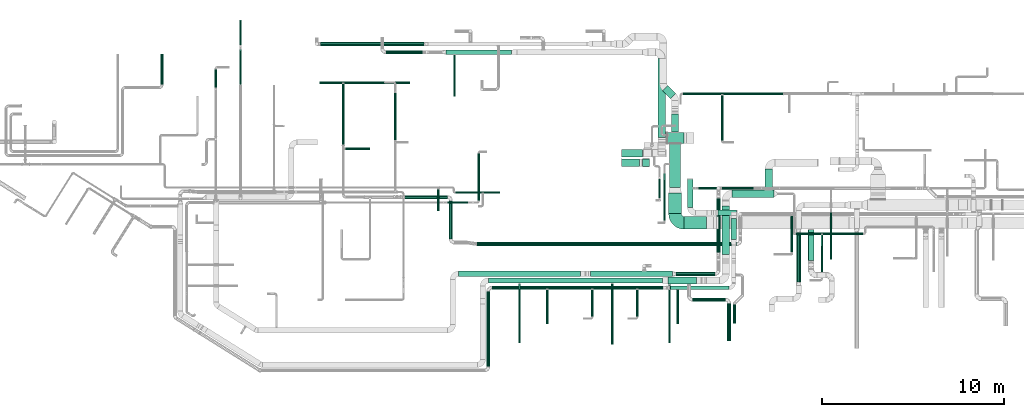
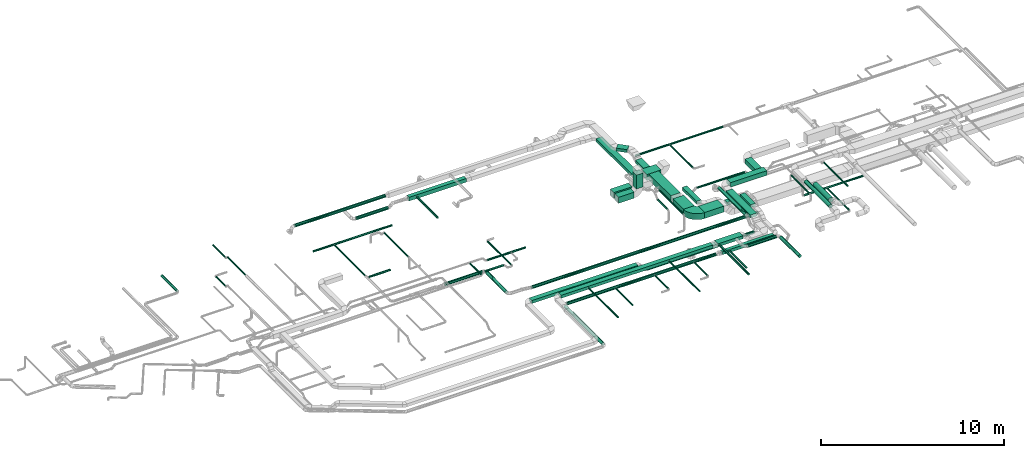
# One storey, part 2 of 60: 65 flow segments, 1 flow fitting.
"""IFC2X3 building model written with IfcOpenShell, lengths in millimetres."""

from ifc_helpers import new_model, entity, si_unit, converted_unit, derived_unit, direction, frame, frame_2d, origin, origin_2d_with_axis, place, context, subcontext, project, spatial, polyline, circle_curve, parameter, trimmed, segment, composite_curve, rectangle, circle, outline, extrude, source, transform, mapped, material, type_object, type_shapes, element, save


model = new_model("IFC2X3")

# Units and contexts
model_context = context("Model", 3, precision=0.01, world=origin(), true_north=direction((6.12303176911189e-17, 1.0)))
body_context = subcontext(model_context, "Body", "Model", "MODEL_VIEW")
ifc_project = project(units=[si_unit("LENGTHUNIT", "METRE", prefix="MILLI"), si_unit("AREAUNIT", "SQUARE_METRE"), si_unit("VOLUMEUNIT", "CUBIC_METRE"), converted_unit("PLANEANGLEUNIT", "DEGREE", entity("IfcRatioMeasure", 0.0174532925199433), si_unit("PLANEANGLEUNIT", "RADIAN"), dimensions=[0, 0, 0, 0, 0, 0, 0]), si_unit("MASSUNIT", "GRAM", prefix="KILO"), derived_unit("MASSDENSITYUNIT", [(si_unit("MASSUNIT", "GRAM", prefix="KILO"), 1), (si_unit("LENGTHUNIT", "METRE"), -3)]), derived_unit("MOMENTOFINERTIAUNIT", [(si_unit("LENGTHUNIT", "METRE"), 4)]), si_unit("TIMEUNIT", "SECOND"), si_unit("FREQUENCYUNIT", "HERTZ"), si_unit("THERMODYNAMICTEMPERATUREUNIT", "DEGREE_CELSIUS"), derived_unit("THERMALTRANSMITTANCEUNIT", [(si_unit("MASSUNIT", "GRAM", prefix="KILO"), 1), (si_unit("THERMODYNAMICTEMPERATUREUNIT", "KELVIN"), -1), (si_unit("TIMEUNIT", "SECOND"), -3)]), derived_unit("VOLUMETRICFLOWRATEUNIT", [(si_unit("LENGTHUNIT", "METRE"), 3), (si_unit("TIMEUNIT", "SECOND"), -1)]), derived_unit("MASSFLOWRATEUNIT", [(si_unit("MASSUNIT", "GRAM", prefix="KILO"), 1), (si_unit("TIMEUNIT", "SECOND"), -1)]), derived_unit("ROTATIONALFREQUENCYUNIT", [(si_unit("TIMEUNIT", "SECOND"), -1)]), si_unit("ELECTRICCURRENTUNIT", "AMPERE"), si_unit("ELECTRICVOLTAGEUNIT", "VOLT"), si_unit("POWERUNIT", "WATT"), si_unit("FORCEUNIT", "NEWTON", prefix="KILO"), si_unit("ILLUMINANCEUNIT", "LUX"), si_unit("LUMINOUSFLUXUNIT", "LUMEN"), si_unit("LUMINOUSINTENSITYUNIT", "CANDELA"), derived_unit("USERDEFINED", [(si_unit("MASSUNIT", "GRAM", prefix="KILO"), -1), (si_unit("LENGTHUNIT", "METRE"), -2), (si_unit("TIMEUNIT", "SECOND"), 3), (si_unit("LUMINOUSFLUXUNIT", "LUMEN"), 1)]), derived_unit("LINEARVELOCITYUNIT", [(si_unit("LENGTHUNIT", "METRE"), 1), (si_unit("TIMEUNIT", "SECOND"), -1)]), si_unit("PRESSUREUNIT", "PASCAL"), derived_unit("USERDEFINED", [(si_unit("LENGTHUNIT", "METRE"), -2), (si_unit("MASSUNIT", "GRAM", prefix="KILO"), 1), (si_unit("TIMEUNIT", "SECOND"), -2)]), derived_unit("LINEARFORCEUNIT", [(si_unit("MASSUNIT", "GRAM", prefix="KILO"), 1), (si_unit("LENGTHUNIT", "METRE"), 1), (si_unit("TIMEUNIT", "SECOND"), -2), (si_unit("LENGTHUNIT", "METRE"), -1)]), derived_unit("PLANARFORCEUNIT", [(si_unit("MASSUNIT", "GRAM", prefix="KILO"), 1), (si_unit("LENGTHUNIT", "METRE"), 1), (si_unit("TIMEUNIT", "SECOND"), -2), (si_unit("LENGTHUNIT", "METRE"), -2)])], contexts=[model_context])

# Site, building, storey
site_placement = place(None, origin())
site = spatial("IfcSite", under=ifc_project, at=site_placement, CompositionType="ELEMENT")
building_placement = place(site_placement, origin())
building = spatial("IfcBuilding", under=site, at=building_placement, CompositionType="ELEMENT")
storey_placement = place(building_placement, frame((0.0, 0.0, 19800.0)))
storey = spatial("IfcBuildingStorey", under=building, at=storey_placement, CompositionType="ELEMENT", Elevation=19800.0)

# Flow segments
duct_segment_type_1 = type_object("IfcDuctSegmentType", PredefinedType="NOTDEFINED")
flow_segment_1_placement = place(storey_placement, frame((31902.9, 5435.05, 3500.0)))
element("IfcFlowSegment", 1, at=flow_segment_1_placement, inside=storey, type_object=duct_segment_type_1, context=body_context, shape_type="SweptSolid", body=[
    extrude(rectangle(XDim=6701.44660940672, YDim=300.0, at=origin_2d_with_axis()), frame((3350.72, 150.0, 0.0)), (0.0, 0.0, 1.0), 199.999999999998),
])
flow_segment_2_placement = place(storey_placement, frame((39161.45, 5435.05, 3150.0)))
element("IfcFlowSegment", 2, at=flow_segment_2_placement, inside=storey, type_object=duct_segment_type_1, context=body_context, shape_type="SweptSolid", body=[
    extrude(rectangle(XDim=4491.44660940676, YDim=300.0, at=origin_2d_with_axis()), frame((2245.72, 150.0, 0.0), z_axis=(0.0, 0.0, 1.0), x_axis=(-1.0, 0.0, 0.0)), (0.0, 0.0, 1.0), 199.999999999998),
])
flow_segment_3_placement = place(storey_placement, frame((48721.97, 10205.34, 3350.0)))
element("IfcFlowSegment", 3, at=flow_segment_3_placement, inside=storey, type_object=duct_segment_type_1, context=body_context, shape_type="SweptSolid", body=[
    extrude(rectangle(XDim=1129.99999999999, YDim=400.000000000004, at=origin_2d_with_axis()), frame((200.0, 565.0, 0.0), z_axis=(0.0, 0.0, 1.0), x_axis=(0.0, -1.0, 0.0)), (0.0, 0.0, 1.0), 300.000000000001),
])
flow_segment_4_placement = place(storey_placement, frame((43391.97, 5025.34, 3500.0)))
element("IfcFlowSegment", 4, at=flow_segment_4_placement, inside=storey, type_object=duct_segment_type_1, context=body_context, shape_type="SweptSolid", body=[
    extrude(rectangle(XDim=1576.57160940675, YDim=400.0, at=origin_2d_with_axis()), frame((788.29, 200.0, 0.0), z_axis=(0.0, 0.0, 1.0), x_axis=(-1.0, 0.0, 0.0)), (0.0, 0.0, 1.0), 199.999999999998),
])
flow_segment_5_placement = place(storey_placement, frame((46370.09, 6645.9, 3400.0)))
element("IfcFlowSegment", 5, at=flow_segment_5_placement, inside=storey, type_object=duct_segment_type_1, context=body_context, shape_type="SweptSolid", body=[
    extrude(rectangle(XDim=2659.44660940663, YDim=400.000000000004, at=origin_2d_with_axis()), frame((200.0, 1329.72, 0.0), z_axis=(0.0, 0.0, 1.0), x_axis=(0.0, -1.0, 0.0)), (0.0, 0.0, 1.0), 199.999999999998),
])
flow_segment_6_placement = place(storey_placement, frame((46920.09, 9785.34, 3350.0)))
element("IfcFlowSegment", 6, at=flow_segment_6_placement, inside=storey, type_object=duct_segment_type_1, context=body_context, shape_type="SweptSolid", body=[
    extrude(rectangle(XDim=2301.875, YDim=400.0, at=origin_2d_with_axis()), frame((1150.94, 200.0, 0.0)), (0.0, 0.0, 1.0), 300.000000000001),
])
flow_segment_7_placement = place(storey_placement, frame((44470.22, 9235.84, 3400.0)))
element("IfcFlowSegment", 7, at=flow_segment_7_placement, inside=storey, type_object=duct_segment_type_1, context=body_context, shape_type="SweptSolid", body=[
    extrude(rectangle(XDim=1545.99428870432, YDim=300.000000000001, at=origin_2d_with_axis()), frame((150.0, 773.0, 0.0), z_axis=(0.0, 0.0, 1.0), x_axis=(0.0, 1.0, 0.0)), (0.0, 0.0, 1.0), 199.999999999998),
])
flow_segment_8_placement = place(storey_placement, frame((43488.88, 4724.52, 3119.89)))
element("IfcFlowSegment", 8, at=flow_segment_8_placement, inside=storey, type_object=duct_segment_type_1, context=body_context, shape_type="SweptSolid", body=[
    extrude(rectangle(XDim=3266.49248887751, YDim=200.000000000001, at=origin_2d_with_axis()), frame((1633.25, 100.0, 0.0), z_axis=(0.0, 0.0, 1.0), x_axis=(-1.0, 0.0, 0.0)), (0.0, 0.0, 1.0), 199.999999999998),
])
flow_segment_9_placement = place(storey_placement, frame((40859.97, 11999.48, 3370.0)))
element("IfcFlowSegment", 9, at=flow_segment_9_placement, inside=storey, type_object=duct_segment_type_1, context=body_context, shape_type="SweptSolid", body=[
    extrude(rectangle(XDim=1150.20548678296, YDim=400.0, at=origin_2d_with_axis()), frame((575.1, 200.0, 0.0), z_axis=(0.0, 0.0, 1.0), x_axis=(-1.0, 0.0, 0.0)), (0.0, 0.0, 1.0), 400.000000000004),
])
flow_segment_10_placement = place(storey_placement, frame((42853.67, 13078.03, 3200.0)))
element("IfcFlowSegment", 10, at=flow_segment_10_placement, inside=storey, type_object=duct_segment_type_1, context=body_context, shape_type="SweptSolid", body=[
    extrude(rectangle(XDim=4322.32864376273, YDim=400.000000000004, at=origin_2d_with_axis()), frame((200.0, 2161.16, 0.0), z_axis=(0.0, 0.0, 1.0), x_axis=(0.0, 1.0, 0.0)), (0.0, 0.0, 1.0), 199.999999999998),
])
flow_segment_11_placement = place(storey_placement, frame((31213.67, 17625.36, 3175.0)))
element("IfcFlowSegment", 11, at=flow_segment_11_placement, inside=storey, type_object=duct_segment_type_1, context=body_context, shape_type="SweptSolid", body=[
    extrude(rectangle(XDim=3599.99999999994, YDim=249.999999999999, at=origin_2d_with_axis()), frame((1800.0, 125.0, 0.0), z_axis=(0.0, 0.0, 1.0), x_axis=(-1.0, 0.0, 0.0)), (0.0, 0.0, 1.0), 250.000000000004),
])
flow_segment_12_placement = place(storey_placement, frame((43366.87, 12737.27, 3250.0)))
element("IfcFlowSegment", 12, at=flow_segment_12_placement, inside=storey, type_object=duct_segment_type_1, context=body_context, shape_type="SweptSolid", body=[
    extrude(rectangle(XDim=903.436285348532, YDim=600.0, at=origin_2d_with_axis()), frame((451.72, 300.0, 0.0), z_axis=(0.0, 0.0, 1.0), x_axis=(-1.0, 0.0, 0.0)), (0.0, 0.0, 1.0), 399.999999999996),
])
flow_segment_13_placement = place(storey_placement, frame((43105.14, 15194.37, 3550.0)))
element("IfcFlowSegment", 13, at=flow_segment_13_placement, inside=storey, type_object=duct_segment_type_1, context=body_context, shape_type="SweptSolid", body=[
    extrude(rectangle(XDim=625.405845398155, YDim=400.000000000001, at=origin_2d_with_axis()), frame((362.54, 362.54, 0.0), z_axis=(0.0, 0.0, 1.0), x_axis=(-0.707106781186548, 0.707106781186548, 0.0)), (0.0, 0.0, 1.0), 199.999999999998),
])
flow_segment_14_placement = place(storey_placement, frame((43591.3, 13357.27, 3350.0)))
element("IfcFlowSegment", 14, at=flow_segment_14_placement, inside=storey, type_object=duct_segment_type_1, context=body_context, shape_type="SweptSolid", body=[
    extrude(rectangle(XDim=1010.48600992803, YDim=399.999999999996, at=origin_2d_with_axis()), frame((200.0, 505.24, 0.0), z_axis=(0.0, 0.0, 1.0), x_axis=(0.0, 1.0, 0.0)), (0.0, 0.0, 1.0), 199.999999999998),
])
flow_segment_15_placement = place(storey_placement, frame((43490.59, 10335.7, 3250.0)))
element("IfcFlowSegment", 15, at=flow_segment_15_placement, inside=storey, type_object=duct_segment_type_1, context=body_context, shape_type="SweptSolid", body=[
    extrude(rectangle(XDim=2381.56802559638, YDim=600.000000000002, at=origin_2d_with_axis()), frame((300.0, 1190.78, 0.0), z_axis=(0.0, 0.0, 1.0), x_axis=(0.0, -1.0, 0.0)), (0.0, 0.0, 1.0), 399.999999999996),
])
flow_segment_16_placement = place(storey_placement, frame((43440.59, 8889.45, 3250.0)))
element("IfcFlowSegment", 16, at=flow_segment_16_placement, inside=storey, type_object=duct_segment_type_1, context=body_context, shape_type="SweptSolid", body=[
    extrude(rectangle(XDim=1146.24999999992, YDim=699.999999999997, at=origin_2d_with_axis()), frame((350.0, 573.12, 0.0), z_axis=(0.0, 0.0, 1.0), x_axis=(0.0, -1.0, 0.0)), (0.0, 0.0, 1.0), 400.000000000004),
])
flow_segment_17_placement = place(storey_placement, frame((44290.59, 8039.45, 3250.0)))
element("IfcFlowSegment", 17, at=flow_segment_17_placement, inside=storey, type_object=duct_segment_type_1, context=body_context, shape_type="SweptSolid", body=[
    extrude(rectangle(XDim=1215.02518618001, YDim=700.0, at=origin_2d_with_axis()), frame((607.51, 350.0, 0.0)), (0.0, 0.0, 1.0), 400.000000000004),
])
flow_segment_18_placement = place(storey_placement, frame((33546.97, 5075.34, 3500.0)))
element("IfcFlowSegment", 18, at=flow_segment_18_placement, inside=storey, type_object=duct_segment_type_1, context=body_context, shape_type="SweptSolid", body=[
    extrude(rectangle(XDim=9544.99999999996, YDim=300.0, at=origin_2d_with_axis()), frame((4772.5, 150.0, 0.0), z_axis=(0.0, 0.0, 1.0), x_axis=(-1.0, 0.0, 0.0)), (0.0, 0.0, 1.0), 199.999999999998),
])
flow_segment_19_placement = place(storey_placement, frame((46855.37, 7462.65, 3410.0)))
element("IfcFlowSegment", 19, at=flow_segment_19_placement, inside=storey, type_object=duct_segment_type_1, context=body_context, shape_type="SweptSolid", body=[
    extrude(rectangle(XDim=1173.37972851492, YDim=300.000000000001, at=origin_2d_with_axis()), frame((150.0, 586.69, 0.0), z_axis=(0.0, 0.0, 1.0), x_axis=(0.0, 1.0, 0.0)), (0.0, 0.0, 1.0), 199.999999999998),
])
flow_segment_20_placement = place(storey_placement, frame((46139.36, 8786.03, 3017.42)))
element("IfcFlowSegment", 20, at=flow_segment_20_placement, inside=storey, type_object=duct_segment_type_1, context=body_context, shape_type="SweptSolid", body=[
    extrude(rectangle(XDim=1027.5, YDim=300.0, at=origin_2d_with_axis()), frame((513.75, 150.0, 0.0)), (0.0, 0.0, 1.0), 199.999999999998),
])
flow_segment_21_placement = place(storey_placement, frame((40859.97, 11490.3, 3370.0)))
element("IfcFlowSegment", 21, at=flow_segment_21_placement, inside=storey, type_object=duct_segment_type_1, context=body_context, shape_type="SweptSolid", body=[
    extrude(rectangle(XDim=987.66925228846, YDim=400.0, at=origin_2d_with_axis()), frame((493.83, 200.0, 0.0)), (0.0, 0.0, 1.0), 400.000000000004),
])
flow_segment_22_placement = place(storey_placement, frame((41997.64, 11490.3, 3920.0)))
element("IfcFlowSegment", 22, at=flow_segment_22_placement, inside=storey, type_object=duct_segment_type_1, context=body_context, shape_type="SweptSolid", body=[
    extrude(rectangle(XDim=399.999999999996, YDim=400.0, at=origin_2d_with_axis()), frame((200.0, 200.0, 0.0)), (0.0, 0.0, 1.0), 929.999975000012),
])
duct_segment_type_2 = type_object("IfcDuctSegmentType", PredefinedType="NOTDEFINED")
flow_segment_23_placement = place(storey_placement, frame((15568.44, 15966.64, 3568.4)))
element("IfcFlowSegment", 23, at=flow_segment_23_placement, inside=storey, type_object=duct_segment_type_2, context=body_context, shape_type="SweptSolid", body=[
    extrude(circle(Radius=80.0, at=origin_2d_with_axis()), frame((81.6, 0.0, 81.6), z_axis=(0.0, 1.0, 0.0), x_axis=(1.0, 0.0, 0.0)), (0.0, 0.0, 1.0), 1673.75000000002),
])
flow_segment_24_placement = place(storey_placement, frame((31747.19, 9998.68, 3598.4)))
element("IfcFlowSegment", 24, at=flow_segment_24_placement, inside=storey, type_object=duct_segment_type_2, context=body_context, shape_type="SweptSolid", body=[
    extrude(circle(Radius=50.0, at=origin_2d_with_axis()), frame((0.0, 51.6, 51.6), z_axis=(1.0, 0.0, 0.0), x_axis=(0.0, -1.0, 0.0)), (0.0, 0.0, 1.0), 2422.49999999999),
])
flow_segment_25_placement = place(storey_placement, frame((30742.73, 9042.46, 3598.4)))
element("IfcFlowSegment", 25, at=flow_segment_25_placement, inside=storey, type_object=duct_segment_type_2, context=body_context, shape_type="SweptSolid", body=[
    extrude(circle(Radius=50.0, at=origin_2d_with_axis()), frame((51.6, 0.0, 51.6), z_axis=(0.0, 1.0, 0.0), x_axis=(-1.0, 0.0, 0.0)), (0.0, 0.0, 1.0), 1199.99999999992),
])
flow_segment_26_placement = place(storey_placement, frame((19903.44, 15963.91, 3148.33)))
element("IfcFlowSegment", 26, at=flow_segment_26_placement, inside=storey, type_object=duct_segment_type_2, context=body_context, shape_type="SweptSolid", body=[
    extrude(circle(Radius=50.0, at=origin_2d_with_axis()), frame((51.6, 0.0, 51.6), z_axis=(0.0, 1.0, 0.0), x_axis=(1.0, 0.0, 0.0)), (0.0, 0.0, 1.0), 1943.57864376271),
])
flow_segment_27_placement = place(storey_placement, frame((19903.44, 18140.26, 2998.4)))
element("IfcFlowSegment", 27, at=flow_segment_27_placement, inside=storey, type_object=duct_segment_type_2, context=body_context, shape_type="SweptSolid", body=[
    extrude(circle(Radius=50.0, at=origin_2d_with_axis()), frame((51.6, 0.0, 51.6), z_axis=(0.0, 1.0, 0.0), x_axis=(1.0, 0.0, 0.0)), (0.0, 0.0, 1.0), 1373.36076977577),
])
flow_segment_28_placement = place(storey_placement, frame((43852.9, 5483.46, 3148.4)))
element("IfcFlowSegment", 28, at=flow_segment_28_placement, inside=storey, type_object=duct_segment_type_2, context=body_context, shape_type="SweptSolid", body=[
    extrude(circle(Radius=100.0, at=origin_2d_with_axis()), frame((0.0, 101.6, 101.6), z_axis=(1.0, 0.0, 0.0), x_axis=(0.0, -1.0, 0.0)), (0.0, 0.0, 1.0), 2117.5),
])
flow_segment_29_placement = place(storey_placement, frame((32973.55, 9600.18, 3098.4)))
element("IfcFlowSegment", 29, at=flow_segment_29_placement, inside=storey, type_object=duct_segment_type_2, context=body_context, shape_type="SweptSolid", body=[
    extrude(circle(Radius=50.0, at=origin_2d_with_axis()), frame((51.6, 0.0, 51.6), z_axis=(0.0, 1.0, 0.0), x_axis=(1.0, 0.0, 0.0)), (0.0, 0.0, 1.0), 2591.87500000001),
])
flow_segment_30_placement = place(storey_placement, frame((31284.07, 9448.58, 3348.4)))
element("IfcFlowSegment", 30, at=flow_segment_30_placement, inside=storey, type_object=duct_segment_type_2, context=body_context, shape_type="SweptSolid", body=[
    extrude(circle(Radius=50.0, at=origin_2d_with_axis()), frame((0.0, 51.6, 51.6), z_axis=(1.0, 0.0, 0.0), x_axis=(0.0, 1.0, 0.0)), (0.0, 0.0, 1.0), 1163.15728752536),
])
flow_segment_31_placement = place(storey_placement, frame((18543.74, 15786.6, 2988.4)))
element("IfcFlowSegment", 31, at=flow_segment_31_placement, inside=storey, type_object=duct_segment_type_2, context=body_context, shape_type="SweptSolid", body=[
    extrude(circle(Radius=50.0, at=origin_2d_with_axis()), frame((51.6, 0.0, 51.6), z_axis=(0.0, 1.0, 0.0), x_axis=(-1.0, 0.0, 0.0)), (0.0, 0.0, 1.0), 1033.57864376272),
])
flow_segment_32_placement = place(storey_placement, frame((50421.97, 7743.75, 2748.4)))
element("IfcFlowSegment", 32, at=flow_segment_32_placement, inside=storey, type_object=duct_segment_type_2, context=body_context, shape_type="SweptSolid", body=[
    extrude(circle(Radius=50.0, at=origin_2d_with_axis()), frame((0.0, 51.6, 51.6), z_axis=(1.0, 0.0, 0.0), x_axis=(0.0, -1.0, 0.0)), (0.0, 0.0, 1.0), 3699.99999999997),
])
flow_segment_33_placement = place(storey_placement, frame((51796.21, 5347.84, 2748.4)))
element("IfcFlowSegment", 33, at=flow_segment_33_placement, inside=storey, type_object=duct_segment_type_2, context=body_context, shape_type="SweptSolid", body=[
    extrude(circle(Radius=50.0, at=origin_2d_with_axis()), frame((51.6, 0.0, 51.6), z_axis=(0.0, 1.0, 0.0), x_axis=(-1.0, 0.0, 0.0)), (0.0, 0.0, 1.0), 2377.49999999999),
])
flow_segment_34_placement = place(storey_placement, frame((28393.66, 12908.73, 3248.73)))
element("IfcFlowSegment", 34, at=flow_segment_34_placement, inside=storey, type_object=duct_segment_type_2, context=body_context, shape_type="SweptSolid", body=[
    extrude(circle(Radius=50.0, at=origin_2d_with_axis()), frame((51.6, 0.0, 51.6), z_axis=(0.0, 1.0, 0.0), x_axis=(1.0, 0.0, 0.0)), (0.0, 0.0, 1.0), 2608.57864376268),
])
flow_segment_35_placement = place(storey_placement, frame((44757.83, 4075.0, 3498.4)))
element("IfcFlowSegment", 35, at=flow_segment_35_placement, inside=storey, type_object=duct_segment_type_2, context=body_context, shape_type="SweptSolid", body=[
    extrude(circle(Radius=100.0, at=origin_2d_with_axis()), frame((0.0, 101.6, 101.6), z_axis=(1.0, 0.0, 0.0), x_axis=(0.0, -1.0, 0.0)), (0.0, 0.0, 1.0), 1790.00000000002),
])
flow_segment_36_placement = place(storey_placement, frame((46646.24, 1905.34, 3498.4)))
element("IfcFlowSegment", 36, at=flow_segment_36_placement, inside=storey, type_object=duct_segment_type_2, context=body_context, shape_type="SweptSolid", body=[
    extrude(circle(Radius=100.0, at=origin_2d_with_axis()), frame((101.6, 0.0, 101.6), z_axis=(0.0, 1.0, 0.0), x_axis=(-1.0, 0.0, 0.0)), (0.0, 0.0, 1.0), 2071.25),
])
flow_segment_37_placement = place(storey_placement, frame((43416.54, 1805.34, 3535.9)))
element("IfcFlowSegment", 37, at=flow_segment_37_placement, inside=storey, type_object=duct_segment_type_2, context=body_context, shape_type="SweptSolid", body=[
    extrude(circle(Radius=62.5, at=origin_2d_with_axis()), frame((64.1, 0.0, 64.1), z_axis=(0.0, 1.0, 0.0), x_axis=(-1.0, 0.0, 0.0)), (0.0, 0.0, 1.0), 3199.99999999998),
])
flow_segment_38_placement = place(storey_placement, frame((40293.64, 1735.34, 3548.4)))
element("IfcFlowSegment", 38, at=flow_segment_38_placement, inside=storey, type_object=duct_segment_type_2, context=body_context, shape_type="SweptSolid", body=[
    extrude(circle(Radius=50.0, at=origin_2d_with_axis()), frame((51.6, 0.0, 51.6), z_axis=(7.11122972929101e-05, 0.999999997471521, 0.0), x_axis=(-0.999999997471521, 7.11122972929101e-05, 0.0)), (0.0, 0.0, 1.0), 3317.84827664515),
])
flow_segment_39_placement = place(storey_placement, frame((35206.08, 1815.34, 3548.4)))
element("IfcFlowSegment", 39, at=flow_segment_39_placement, inside=storey, type_object=duct_segment_type_2, context=body_context, shape_type="SweptSolid", body=[
    extrude(circle(Radius=50.0, at=origin_2d_with_axis()), frame((51.6, 0.0, 51.6), z_axis=(0.0, 1.0, 0.0), x_axis=(-1.0, 0.0, 0.0)), (0.0, 0.0, 1.0), 3239.99999999997),
])
flow_segment_40_placement = place(storey_placement, frame((33745.37, 4722.93, 3128.29)))
element("IfcFlowSegment", 40, at=flow_segment_40_placement, inside=storey, type_object=duct_segment_type_2, context=body_context, shape_type="SweptSolid", body=[
    extrude(circle(Radius=100.0, at=origin_2d_with_axis()), frame((0.0, 101.6, 101.6), z_axis=(1.0, 0.0, 0.0), x_axis=(0.0, -1.0, 0.0)), (0.0, 0.0, 1.0), 9379.8571661075),
])
flow_segment_41_placement = place(storey_placement, frame((33443.78, 500.15, 3128.29)))
element("IfcFlowSegment", 41, at=flow_segment_41_placement, inside=storey, type_object=duct_segment_type_2, context=body_context, shape_type="SweptSolid", body=[
    extrude(circle(Radius=100.0, at=origin_2d_with_axis()), frame((101.6, 0.0, 101.6), z_axis=(0.0, 1.0, 0.0), x_axis=(-1.0, 0.0, 0.0)), (0.0, 0.0, 1.0), 4124.37499999996),
])
flow_segment_42_placement = place(storey_placement, frame((36723.62, 2864.52, 3198.4)))
element("IfcFlowSegment", 42, at=flow_segment_42_placement, inside=storey, type_object=duct_segment_type_2, context=body_context, shape_type="SweptSolid", body=[
    extrude(circle(Radius=50.0, at=origin_2d_with_axis()), frame((51.6, 0.0, 51.6), z_axis=(0.0, 1.0, 0.0), x_axis=(-1.0, 0.0, 0.0)), (0.0, 0.0, 1.0), 1841.99752351175),
])
flow_segment_43_placement = place(storey_placement, frame((39193.38, 3236.76, 3198.4)))
element("IfcFlowSegment", 43, at=flow_segment_43_placement, inside=storey, type_object=duct_segment_type_2, context=body_context, shape_type="SweptSolid", body=[
    extrude(circle(Radius=50.0, at=origin_2d_with_axis()), frame((51.6, 0.0, 51.6), z_axis=(0.0, 1.0, 0.0), x_axis=(1.0, 0.0, 0.0)), (0.0, 0.0, 1.0), 1469.76072571642),
])
flow_segment_44_placement = place(storey_placement, frame((41666.89, 3239.52, 3198.4)))
element("IfcFlowSegment", 44, at=flow_segment_44_placement, inside=storey, type_object=duct_segment_type_2, context=body_context, shape_type="SweptSolid", body=[
    extrude(circle(Radius=50.0, at=origin_2d_with_axis()), frame((51.6, 0.0, 51.6), z_axis=(0.0, 1.0, 0.0), x_axis=(-1.0, 0.0, 0.0)), (0.0, 0.0, 1.0), 1466.99752351176),
])
flow_segment_45_placement = place(storey_placement, frame((43867.39, 2844.52, 3185.9)))
element("IfcFlowSegment", 45, at=flow_segment_45_placement, inside=storey, type_object=duct_segment_type_2, context=body_context, shape_type="SweptSolid", body=[
    extrude(circle(Radius=62.5, at=origin_2d_with_axis()), frame((64.1, 0.0, 64.1), z_axis=(0.0, 1.0, 0.0), x_axis=(-1.0, 0.0, 0.0)), (0.0, 0.0, 1.0), 1859.99999999998),
])
flow_segment_46_placement = place(storey_placement, frame((46975.37, 2877.54, 3138.29)))
element("IfcFlowSegment", 46, at=flow_segment_46_placement, inside=storey, type_object=duct_segment_type_2, context=body_context, shape_type="SweptSolid", body=[
    extrude(circle(Radius=80.0, at=origin_2d_with_axis()), frame((81.6, 0.0, 81.6), z_axis=(0.0, 1.0, 0.0), x_axis=(-1.0, 0.0, 0.0)), (0.0, 0.0, 1.0), 1028.72583002031),
])
flow_segment_47_placement = place(storey_placement, frame((27931.17, 17648.76, 2998.4)))
element("IfcFlowSegment", 47, at=flow_segment_47_placement, inside=storey, type_object=duct_segment_type_2, context=body_context, shape_type="SweptSolid", body=[
    extrude(circle(Radius=100.0, at=origin_2d_with_axis()), frame((0.0, 101.6, 101.6), z_axis=(1.0, 0.0, 0.0), x_axis=(0.0, 1.0, 0.0)), (0.0, 0.0, 1.0), 2011.1572875254),
])
flow_segment_48_placement = place(storey_placement, frame((31625.83, 15325.36, 3235.9)))
element("IfcFlowSegment", 48, at=flow_segment_48_placement, inside=storey, type_object=duct_segment_type_2, context=body_context, shape_type="SweptSolid", body=[
    extrude(circle(Radius=62.5, at=origin_2d_with_axis()), frame((64.1, 0.0, 64.1), z_axis=(0.0, 1.0, 0.0), x_axis=(-1.0, 0.0, 0.0)), (0.0, 0.0, 1.0), 2279.99999999998),
])
flow_segment_49_placement = place(storey_placement, frame((42876.46, 9750.73, 3235.9)))
element("IfcFlowSegment", 49, at=flow_segment_49_placement, inside=storey, type_object=duct_segment_type_2, context=body_context, shape_type="SweptSolid", body=[
    extrude(circle(Radius=62.5, at=origin_2d_with_axis()), frame((64.1, 0.0, 64.1), z_axis=(0.0, 1.0, 0.0), x_axis=(1.0, 0.0, 0.0)), (0.0, 0.0, 1.0), 1036.9733047033),
])
flow_segment_50_placement = place(storey_placement, frame((24333.07, 18098.59, 3498.4)))
element("IfcFlowSegment", 50, at=flow_segment_50_placement, inside=storey, type_object=duct_segment_type_2, context=body_context, shape_type="SweptSolid", body=[
    extrude(circle(Radius=100.0, at=origin_2d_with_axis()), frame((0.0, 101.6, 101.6), z_axis=(1.0, 0.0, 0.0), x_axis=(0.0, -1.0, 0.0)), (0.0, 0.0, 1.0), 5695.00000000003),
])
flow_segment_51_placement = place(storey_placement, frame((51088.84, 6319.98, 2940.86)))
element("IfcFlowSegment", 51, at=flow_segment_51_placement, inside=storey, type_object=duct_segment_type_2, context=body_context, shape_type="SweptSolid", body=[
    extrude(circle(Radius=157.5, at=origin_2d_with_axis()), frame((159.1, 0.0, 159.1), z_axis=(0.0, 1.0, 0.0), x_axis=(-1.0, 0.0, 0.0)), (0.0, 0.0, 1.0), 1699.47425391344),
])
flow_segment_52_placement = place(storey_placement, frame((43158.68, 8490.64, 3598.4)))
element("IfcFlowSegment", 52, at=flow_segment_52_placement, inside=storey, type_object=duct_segment_type_2, context=body_context, shape_type="SweptSolid", body=[
    extrude(circle(Radius=50.0, at=origin_2d_with_axis()), frame((51.6, 0.0, 51.6), z_axis=(0.0, 1.0, 0.0), x_axis=(1.0, 0.0, 0.0)), (0.0, 0.0, 1.0), 2606.07864376266),
])
flow_segment_53_placement = place(storey_placement, frame((50438.78, 5156.06, 3493.4)))
element("IfcFlowSegment", 53, at=flow_segment_53_placement, inside=storey, type_object=duct_segment_type_2, context=body_context, shape_type="SweptSolid", body=[
    extrude(circle(Radius=125.0, at=origin_2d_with_axis()), frame((126.6, 0.0, 126.6), z_axis=(0.0, 1.0, 0.0), x_axis=(-1.0, 0.0, 0.0)), (0.0, 0.0, 1.0), 2700.0),
])
flow_segment_54_placement = place(storey_placement, frame((44216.09, 15411.64, 2885.9)))
element("IfcFlowSegment", 54, at=flow_segment_54_placement, inside=storey, type_object=duct_segment_type_2, context=body_context, shape_type="SweptSolid", body=[
    extrude(circle(Radius=62.5, at=origin_2d_with_axis()), frame((0.0, 64.1, 64.1), z_axis=(1.0, 0.0, 0.0), x_axis=(0.0, 1.0, 0.0)), (0.0, 0.0, 1.0), 5510.0),
])
flow_segment_55_placement = place(storey_placement, frame((46318.63, 12900.73, 2898.4)))
element("IfcFlowSegment", 55, at=flow_segment_55_placement, inside=storey, type_object=duct_segment_type_2, context=body_context, shape_type="SweptSolid", body=[
    extrude(circle(Radius=50.0, at=origin_2d_with_axis()), frame((51.6, 0.0, 51.6), z_axis=(0.0, 1.0, 0.0), x_axis=(-1.0, 0.0, 0.0)), (0.0, 0.0, 1.0), 2492.49999999943),
])
flow_segment_56_placement = place(storey_placement, frame((25538.65, 12670.01, 3133.4)))
element("IfcFlowSegment", 56, at=flow_segment_56_placement, inside=storey, type_object=duct_segment_type_2, context=body_context, shape_type="SweptSolid", body=[
    extrude(circle(Radius=50.0, at=origin_2d_with_axis()), frame((51.6, 0.0, 51.6), z_axis=(0.0, 1.0, 0.0), x_axis=(1.0, 0.0, 0.0)), (0.0, 0.0, 1.0), 3334.99999999997),
])
flow_segment_57_placement = place(storey_placement, frame((50137.46, 6773.01, 3548.4)))
element("IfcFlowSegment", 57, at=flow_segment_57_placement, inside=storey, type_object=duct_segment_type_2, context=body_context, shape_type="SweptSolid", body=[
    extrude(circle(Radius=50.0, at=origin_2d_with_axis()), frame((51.6, 0.0, 51.6), z_axis=(0.0, 1.0, 0.0), x_axis=(1.0, 0.0, 0.0)), (0.0, 0.0, 1.0), 2006.9958710171),
])
flow_segment_58_placement = place(storey_placement, frame((25688.83, 12398.88, 3148.4)))
element("IfcFlowSegment", 58, at=flow_segment_58_placement, inside=storey, type_object=duct_segment_type_2, context=body_context, shape_type="SweptSolid", body=[
    extrude(circle(Radius=50.0, at=origin_2d_with_axis()), frame((0.0, 51.6, 51.6), z_axis=(1.0, 0.0, 0.0), x_axis=(0.0, -1.0, 0.0)), (0.0, 0.0, 1.0), 1341.41883177248),
])
flow_segment_59_placement = place(storey_placement, frame((24290.25, 16023.41, 3148.4)))
element("IfcFlowSegment", 59, at=flow_segment_59_placement, inside=storey, type_object=duct_segment_type_2, context=body_context, shape_type="SweptSolid", body=[
    extrude(circle(Radius=50.0, at=origin_2d_with_axis()), frame((0.0, 51.6, 51.6), z_axis=(1.0, 0.0, 0.0), x_axis=(0.0, 1.0, 0.0)), (0.0, 0.0, 1.0), 4951.71249680004),
])
flow_segment_60_placement = place(storey_placement, frame((31393.96, 7506.9, 3046.92)))
element("IfcFlowSegment", 60, at=flow_segment_60_placement, inside=storey, type_object=duct_segment_type_2, context=body_context, shape_type="SweptSolid", body=[
    extrude(circle(Radius=100.0, at=origin_2d_with_axis()), frame((101.6, 3.34, 101.58), z_axis=(0.0, 0.99984752411518, 0.0174622026315378), x_axis=(1.0, 0.0, 0.0)), (0.0, 0.0, 1.0), 2090.36934246395),
])
flow_segment_61_placement = place(storey_placement, frame((32926.17, 7123.41, 3043.41)))
element("IfcFlowSegment", 61, at=flow_segment_61_placement, inside=storey, type_object=duct_segment_type_2, context=body_context, shape_type="SweptSolid", body=[
    extrude(circle(Radius=100.0, at=origin_2d_with_axis()), frame((0.0, 101.6, 101.6), z_axis=(1.0, 0.0, 0.0), x_axis=(0.0, 1.0, 0.0)), (0.0, 0.0, 1.0), 14244.3841390235),
])
flow_segment_62_placement = place(storey_placement, frame((28956.89, 9698.72, 3083.4)))
element("IfcFlowSegment", 62, at=flow_segment_62_placement, inside=storey, type_object=duct_segment_type_2, context=body_context, shape_type="SweptSolid", body=[
    extrude(circle(Radius=100.0, at=origin_2d_with_axis()), frame((0.0, 101.6, 101.6), z_axis=(1.0, 0.0, 0.0), x_axis=(0.0, 1.0, 0.0)), (0.0, 0.0, 1.0), 2338.66950048254),
])
flow_segment_63_placement = place(storey_placement, frame((52295.4, 6384.6, 3548.4)))
element("IfcFlowSegment", 63, at=flow_segment_63_placement, inside=storey, type_object=duct_segment_type_2, context=body_context, shape_type="SweptSolid", body=[
    extrude(circle(Radius=50.0, at=origin_2d_with_axis()), frame((51.6, 0.0, 51.6), z_axis=(0.0, 1.0, 0.0), x_axis=(1.0, 0.0, 0.0)), (0.0, 0.0, 1.0), 2577.15728752539),
])
flow_segment_64_placement = place(storey_placement, frame((46068.81, 6758.9, 3518.4)))
element("IfcFlowSegment", 64, at=flow_segment_64_placement, inside=storey, type_object=duct_segment_type_2, context=body_context, shape_type="SweptSolid", body=[
    extrude(circle(Radius=100.0, at=origin_2d_with_axis()), frame((101.6, 0.0, 101.6), z_axis=(0.0, 1.0, 0.0), x_axis=(1.0, 0.0, 0.0)), (0.0, 0.0, 1.0), 2953.88115918347),
])
flow_segment_65_placement = place(storey_placement, frame((45074.48, 10221.52, 3585.9)))
element("IfcFlowSegment", 65, at=flow_segment_65_placement, inside=storey, type_object=duct_segment_type_2, context=body_context, shape_type="SweptSolid", body=[
    extrude(circle(Radius=62.5, at=origin_2d_with_axis()), frame((0.0, 64.1, 64.1), z_axis=(1.0, 0.0, 0.0), x_axis=(0.0, 1.0, 0.0)), (0.0, 0.0, 1.0), 3025.48701564935),
])

# Flow fitting
ifc_material = material()
duct_fitting_type = type_object("IfcDuctFittingType", PredefinedType="NOTDEFINED", material=ifc_material)
shared_shape = source(origin(), body_context, "Body", "SweptSolid", [
    extrude(outline(composite_curve([segment(polyline([(-600.0, -250.0), (100.0, -250.0)]), True, "CONTINUOUS"), segment(trimmed(circle_curve(frame_2d((250.0, -250.0), x_axis=(0.0, 1.0)), 150.0), [parameter(0.0)], [parameter(90.0000000000016)], True, "PARAMETER"), False, "CONTINUOUS"), segment(polyline([(250.0, -100.0), (250.0, 600.0)]), True, "CONTINUOUS"), segment(trimmed(circle_curve(frame_2d((250.0, -250.0), x_axis=(0.0, 1.0)), 850.0), [parameter(0.0)], [parameter(90.0000000000016)], True, "PARAMETER"), True, "CONTINUOUS")], self_intersect=False)), frame((-250.0, 250.0, -200.0), z_axis=(0.0, 0.0, 1.0), x_axis=(-1.0, 0.0, 0.0)), (0.0, 0.0, 1.0), 400.0),
])
type_shapes(duct_fitting_type, [shared_shape])
flow_fitting_placement = place(storey_placement, frame((43790.59, 8389.45, 3450.0), z_axis=(0.0, 0.0, 1.0), x_axis=(0.0, -1.0, 0.0)))
element("IfcFlowFitting", 66, at=flow_fitting_placement, inside=storey, type_object=duct_fitting_type, material=ifc_material, context=body_context, shape_type="MappedRepresentation", body=[
    mapped(shared_shape, transform((0.0, 0.0, 0.0), scale=1.0)),
])

save(model, "model.ifc")
